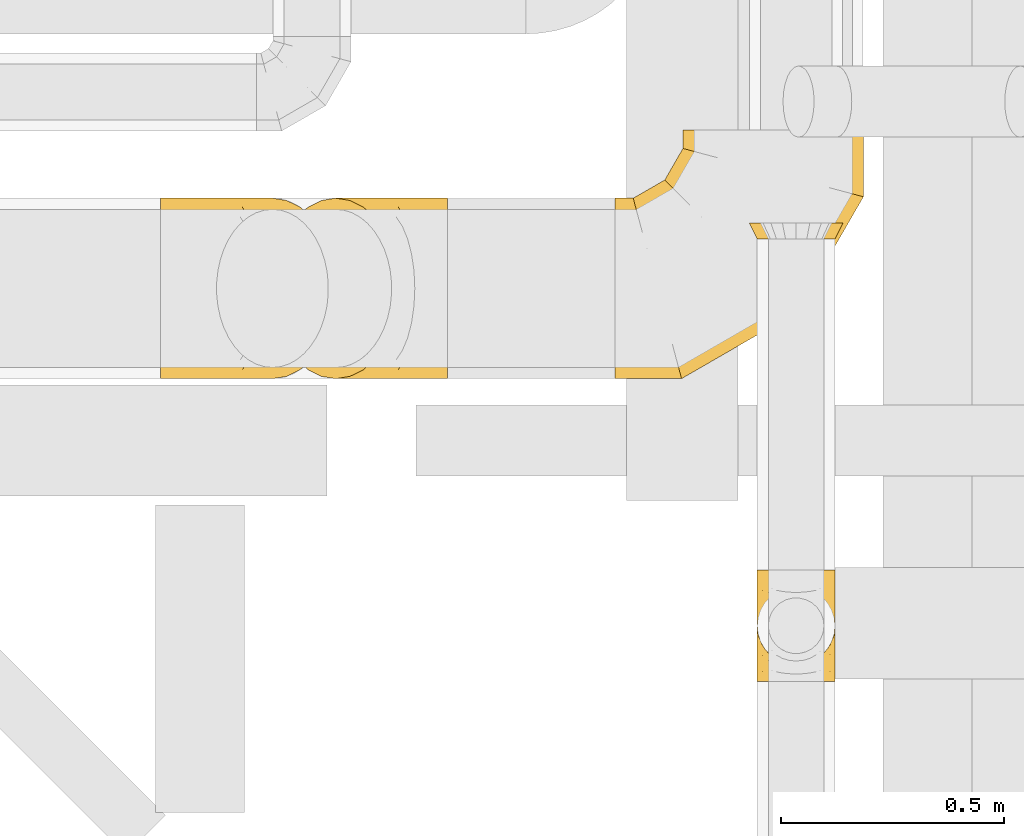
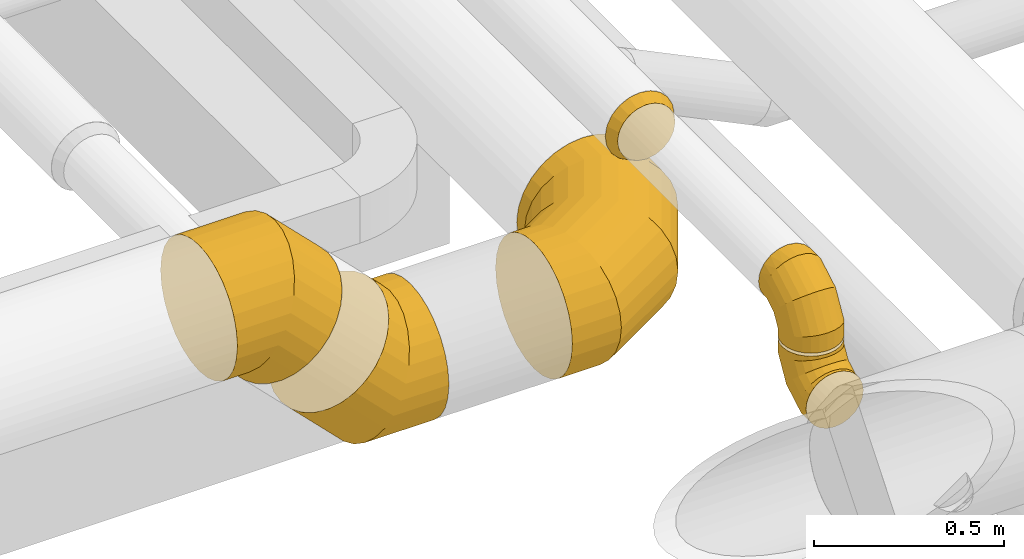
# One storey, part 12 of 337: 6 coverings.
"""IFC2X3 building model written with IfcOpenShell, lengths in millimetres."""

from ifc_helpers import new_model, entity, si_unit, converted_unit, derived_unit, direction, frame, origin, place, context, subcontext, project, spatial, faceted_brep, element, save


model = new_model("IFC2X3")

# Units and contexts
model_context = context("Model", 3, precision=0.01, world=origin(), true_north=direction((6.12303176911189e-17, 1.0)))
body_context = subcontext(model_context, "Body", "Model", "MODEL_VIEW")
ifc_project = project(units=[si_unit("LENGTHUNIT", "METRE", prefix="MILLI"), si_unit("AREAUNIT", "SQUARE_METRE"), si_unit("VOLUMEUNIT", "CUBIC_METRE"), converted_unit("PLANEANGLEUNIT", "DEGREE", entity("IfcRatioMeasure", 0.0174532925199433), si_unit("PLANEANGLEUNIT", "RADIAN"), dimensions=[0, 0, 0, 0, 0, 0, 0]), si_unit("MASSUNIT", "GRAM", prefix="KILO"), derived_unit("MASSDENSITYUNIT", [(si_unit("MASSUNIT", "GRAM", prefix="KILO"), 1), (si_unit("LENGTHUNIT", "METRE"), -3)]), derived_unit("MOMENTOFINERTIAUNIT", [(si_unit("LENGTHUNIT", "METRE"), 4)]), si_unit("TIMEUNIT", "SECOND"), si_unit("FREQUENCYUNIT", "HERTZ"), si_unit("THERMODYNAMICTEMPERATUREUNIT", "DEGREE_CELSIUS"), derived_unit("THERMALTRANSMITTANCEUNIT", [(si_unit("MASSUNIT", "GRAM", prefix="KILO"), 1), (si_unit("THERMODYNAMICTEMPERATUREUNIT", "KELVIN"), -1), (si_unit("TIMEUNIT", "SECOND"), -3)]), derived_unit("VOLUMETRICFLOWRATEUNIT", [(si_unit("LENGTHUNIT", "METRE"), 3), (si_unit("TIMEUNIT", "SECOND"), -1)]), derived_unit("MASSFLOWRATEUNIT", [(si_unit("MASSUNIT", "GRAM", prefix="KILO"), 1), (si_unit("TIMEUNIT", "SECOND"), -1)]), derived_unit("ROTATIONALFREQUENCYUNIT", [(si_unit("TIMEUNIT", "SECOND"), -1)]), si_unit("ELECTRICCURRENTUNIT", "AMPERE"), si_unit("ELECTRICVOLTAGEUNIT", "VOLT"), si_unit("POWERUNIT", "WATT"), si_unit("FORCEUNIT", "NEWTON", prefix="KILO"), si_unit("ILLUMINANCEUNIT", "LUX"), si_unit("LUMINOUSFLUXUNIT", "LUMEN"), si_unit("LUMINOUSINTENSITYUNIT", "CANDELA"), derived_unit("USERDEFINED", [(si_unit("MASSUNIT", "GRAM", prefix="KILO"), -1), (si_unit("LENGTHUNIT", "METRE"), -2), (si_unit("TIMEUNIT", "SECOND"), 3), (si_unit("LUMINOUSFLUXUNIT", "LUMEN"), 1)]), derived_unit("LINEARVELOCITYUNIT", [(si_unit("LENGTHUNIT", "METRE"), 1), (si_unit("TIMEUNIT", "SECOND"), -1)]), si_unit("PRESSUREUNIT", "PASCAL"), derived_unit("USERDEFINED", [(si_unit("LENGTHUNIT", "METRE"), -2), (si_unit("MASSUNIT", "GRAM", prefix="KILO"), 1), (si_unit("TIMEUNIT", "SECOND"), -2)]), derived_unit("LINEARFORCEUNIT", [(si_unit("MASSUNIT", "GRAM", prefix="KILO"), 1), (si_unit("LENGTHUNIT", "METRE"), 1), (si_unit("TIMEUNIT", "SECOND"), -2), (si_unit("LENGTHUNIT", "METRE"), -1)]), derived_unit("PLANARFORCEUNIT", [(si_unit("MASSUNIT", "GRAM", prefix="KILO"), 1), (si_unit("LENGTHUNIT", "METRE"), 1), (si_unit("TIMEUNIT", "SECOND"), -2), (si_unit("LENGTHUNIT", "METRE"), -2)])], contexts=[model_context])

# Site, building, storey
site_placement = place(None, origin())
site = spatial("IfcSite", under=ifc_project, at=site_placement, CompositionType="ELEMENT")
building_placement = place(site_placement, origin())
building = spatial("IfcBuilding", under=site, at=building_placement, CompositionType="ELEMENT")
storey_placement = place(building_placement, origin())
storey = spatial("IfcBuildingStorey", under=building, at=storey_placement, CompositionType="ELEMENT", Elevation=0.0)

# Coverings
covering_1_placement = place(storey_placement, frame((65645.58, 2582.18, 3050.9)))
element("IfcCovering", 1, at=covering_1_placement, inside=storey, PredefinedType="INSULATION", context=body_context, shape_type="Brep", body=[
    faceted_brep([(172.31, 97.96, 214.1), (176.6, 125.0, 214.1), (172.31, 152.04, 214.1), (159.88, 176.43, 214.1), (140.53, 195.79, 214.1), (116.13, 208.22, 214.1), (89.1, 212.5, 214.1), (62.06, 208.22, 214.1), (37.66, 195.79, 214.1), (18.31, 176.43, 214.1), (5.88, 152.04, 214.1), (1.6, 125.0, 214.1), (5.88, 97.96, 214.1), (18.31, 73.57, 214.1), (37.66, 54.21, 214.1), (49.86, 48.0, 214.1), (62.06, 41.78, 214.1), (75.58, 39.64, 214.1), (89.1, 37.5, 214.1), (102.61, 39.64, 214.1), (116.13, 41.78, 214.1), (128.33, 48.0, 214.1), (140.53, 54.21, 214.1), (159.88, 73.57, 214.1), (45.35, 0.0, 13.32), (66.45, 0.0, 4.58), (89.1, 0.0, 1.6), (111.74, 0.0, 4.58), (132.85, 0.0, 13.32), (150.97, 0.0, 27.22), (164.87, 0.0, 45.35), (173.61, 0.0, 66.45), (176.6, 0.0, 89.1), (173.61, 0.0, 111.74), (164.87, 0.0, 132.85), (150.97, 0.0, 150.97), (132.85, 0.0, 164.87), (111.74, 0.0, 173.61), (89.1, 0.0, 176.6), (66.45, 0.0, 173.61), (45.35, 0.0, 164.87), (27.22, 0.0, 150.97), (13.32, 0.0, 132.85), (4.58, 0.0, 111.74), (1.6, 0.0, 89.1), (4.58, 0.0, 66.45), (13.32, 0.0, 45.35), (27.22, 0.0, 27.22), (89.1, 56.94, 1.6), (111.74, 56.14, 4.58), (132.85, 53.8, 13.32), (150.97, 50.07, 27.22), (164.87, 45.22, 45.35), (173.61, 39.56, 66.45), (176.6, 33.49, 89.1), (173.61, 27.43, 111.74), (164.87, 21.77, 132.85), (150.97, 16.92, 150.97), (132.85, 13.19, 164.87), (111.74, 10.85, 173.61), (89.1, 10.05, 176.6), (66.45, 10.85, 173.61), (45.35, 13.19, 164.87), (27.22, 16.92, 150.97), (4.58, 27.43, 111.74), (1.6, 33.49, 89.1), (13.32, 21.77, 132.85), (4.58, 39.56, 66.45), (13.32, 45.22, 45.35), (27.22, 50.07, 27.22), (45.35, 53.8, 13.32), (66.45, 56.14, 4.58), (89.1, 155.56, 58.53), (111.74, 153.38, 60.72), (132.85, 146.98, 67.12), (150.97, 136.8, 77.3), (164.87, 123.53, 90.56), (173.61, 108.08, 106.01), (176.6, 91.51, 122.59), (173.61, 74.93, 139.17), (164.87, 59.48, 154.62), (150.97, 46.21, 167.88), (132.85, 36.03, 178.06), (111.74, 29.63, 184.46), (89.1, 27.45, 186.64), (66.45, 29.63, 184.46), (45.35, 36.03, 178.06), (27.22, 46.21, 167.88), (4.58, 74.93, 139.17), (1.6, 91.51, 122.59), (13.32, 59.48, 154.62), (4.58, 108.08, 106.01), (13.32, 123.53, 90.56), (27.22, 136.8, 77.3), (45.35, 146.98, 67.12), (66.45, 153.38, 60.72), (89.1, 212.5, 157.16), (111.74, 209.52, 157.95), (132.85, 200.78, 160.3), (150.97, 186.87, 164.02), (164.87, 168.75, 168.88), (173.61, 147.65, 174.53), (176.6, 125.0, 180.6), (173.61, 102.35, 186.67), (164.87, 81.25, 192.32), (150.97, 63.13, 197.18), (132.85, 49.22, 200.91), (111.74, 40.48, 203.25), (100.42, 38.99, 203.65), (89.1, 37.5, 204.05), (66.45, 40.48, 203.25), (45.35, 49.22, 200.91), (77.77, 38.99, 203.65), (27.22, 63.13, 197.18), (4.58, 102.35, 186.67), (1.6, 125.0, 180.6), (13.32, 81.25, 192.32), (4.58, 147.65, 174.53), (13.32, 168.75, 168.88), (27.22, 186.87, 164.02), (45.35, 200.78, 160.3), (66.45, 209.52, 157.95)], [[[0, 1, 2, 3, 4, 5, 6, 7, 8, 9, 10, 11, 12, 13, 14, 15, 16, 17, 18, 19, 20, 21, 22, 23]], [[24, 25, 26, 27, 28, 29, 30, 31, 32, 33, 34, 35, 36, 37, 38, 39, 40, 41, 42, 43, 44, 45, 46, 47]], [[26, 48, 49, 27]], [[27, 49, 50, 28]], [[28, 50, 51, 29]], [[30, 52, 53, 31]], [[31, 53, 54, 32]], [[29, 51, 52, 30]], [[55, 56, 34, 33]], [[54, 55, 33, 32]], [[57, 35, 34, 56]], [[58, 59, 37, 36]], [[58, 36, 35, 57]], [[60, 38, 37, 59]], [[61, 62, 40, 39]], [[60, 61, 39, 38]], [[41, 40, 62, 63]], [[64, 65, 44, 43]], [[66, 64, 43, 42]], [[63, 66, 42, 41]], [[46, 45, 67, 68]], [[47, 46, 68, 69]], [[44, 65, 67, 45]], [[25, 24, 70, 71]], [[26, 25, 71, 48]], [[69, 70, 24, 47]], [[49, 48, 72, 73]], [[50, 49, 73, 74]], [[74, 75, 51, 50]], [[52, 51, 75, 76]], [[53, 52, 76, 77]], [[54, 53, 77, 78]], [[79, 80, 56, 55]], [[78, 79, 55, 54]], [[57, 56, 80, 81]], [[82, 83, 59, 58]], [[81, 82, 58, 57]], [[60, 59, 83, 84]], [[85, 86, 62, 61]], [[84, 85, 61, 60]], [[63, 62, 86, 87]], [[88, 89, 65, 64]], [[90, 88, 64, 66]], [[87, 90, 66, 63]], [[67, 65, 89, 91]], [[68, 67, 91, 92]], [[69, 68, 92, 93]], [[71, 70, 94, 95]], [[48, 71, 95, 72]], [[93, 94, 70, 69]], [[73, 72, 96, 97]], [[74, 73, 97, 98]], [[98, 99, 75, 74]], [[76, 75, 99, 100]], [[77, 76, 100, 101]], [[78, 77, 101, 102]], [[103, 104, 80, 79]], [[102, 103, 79, 78]], [[81, 80, 104, 105]], [[106, 107, 83, 82]], [[105, 106, 82, 81]], [[84, 83, 107, 108, 109]], [[110, 111, 86, 85]], [[85, 84, 109, 112, 110]], [[87, 86, 111, 113]], [[114, 115, 89, 88]], [[116, 114, 88, 90]], [[113, 116, 90, 87]], [[91, 89, 115, 117]], [[92, 91, 117, 118]], [[93, 92, 118, 119]], [[95, 94, 120, 121]], [[72, 95, 121, 96]], [[119, 120, 94, 93]], [[97, 6, 5]], [[98, 5, 4]], [[6, 97, 96]], [[97, 5, 98]], [[4, 99, 98]], [[100, 3, 2]], [[101, 2, 1]], [[99, 3, 100]], [[100, 2, 101]], [[1, 102, 101]], [[3, 99, 4]], [[103, 1, 0]], [[104, 0, 23]], [[103, 102, 1]], [[104, 103, 0]], [[23, 105, 104]], [[21, 20, 107]], [[18, 109, 108]], [[107, 20, 19]], [[106, 105, 22]], [[106, 22, 21]], [[107, 19, 108]], [[21, 107, 106]], [[18, 108, 19]], [[22, 105, 23]], [[110, 17, 16]], [[111, 15, 14]], [[18, 112, 109]], [[18, 17, 112]], [[110, 16, 15]], [[110, 15, 111]], [[14, 113, 111]], [[116, 13, 12]], [[114, 12, 11]], [[116, 113, 13]], [[115, 114, 11]], [[116, 12, 114]], [[17, 110, 112]], [[13, 113, 14]], [[117, 11, 10]], [[118, 10, 9]], [[11, 117, 115]], [[117, 10, 118]], [[9, 119, 118]], [[120, 8, 7]], [[121, 7, 6]], [[119, 8, 120]], [[121, 120, 7]], [[96, 121, 6]], [[8, 119, 9]]]),
])
covering_2_placement = place(storey_placement, frame((65645.58, 2618.09, 3275.0)))
element("IfcCovering", 2, at=covering_2_placement, inside=storey, PredefinedType="INSULATION", context=body_context, shape_type="Brep", body=[
    faceted_brep([(5.88, 214.1, 97.96), (1.6, 214.1, 125.0), (5.88, 214.1, 152.04), (18.31, 214.1, 176.43), (37.66, 214.1, 195.79), (62.06, 214.1, 208.22), (89.1, 214.1, 212.5), (116.13, 214.1, 208.22), (140.53, 214.1, 195.79), (159.88, 214.1, 176.43), (172.31, 214.1, 152.04), (176.6, 214.1, 125.0), (172.31, 214.1, 97.96), (159.88, 214.1, 73.57), (140.53, 214.1, 54.21), (128.33, 214.1, 48.0), (116.13, 214.1, 41.78), (102.61, 214.1, 39.64), (89.1, 214.1, 37.5), (75.58, 214.1, 39.64), (62.06, 214.1, 41.78), (49.86, 214.1, 48.0), (37.66, 214.1, 54.21), (18.31, 214.1, 73.57), (132.85, 13.32, 0.0), (111.74, 4.58, 0.0), (89.1, 1.6, 0.0), (66.45, 4.58, 0.0), (45.35, 13.32, 0.0), (27.22, 27.22, 0.0), (13.32, 45.35, 0.0), (4.58, 66.45, 0.0), (1.6, 89.1, 0.0), (4.58, 111.74, 0.0), (13.32, 132.85, 0.0), (27.22, 150.97, 0.0), (45.35, 164.87, 0.0), (66.45, 173.61, 0.0), (89.1, 176.6, 0.0), (111.74, 173.61, 0.0), (132.85, 164.87, 0.0), (150.97, 150.97, 0.0), (164.87, 132.85, 0.0), (173.61, 111.74, 0.0), (176.6, 89.1, 0.0), (173.61, 66.45, 0.0), (164.87, 45.35, 0.0), (150.97, 27.22, 0.0), (89.1, 1.6, 56.94), (66.45, 4.58, 56.14), (45.35, 13.32, 53.8), (27.22, 27.22, 50.07), (13.32, 45.35, 45.22), (4.58, 66.45, 39.56), (1.6, 89.1, 33.49), (4.58, 111.74, 27.43), (13.32, 132.85, 21.77), (27.22, 150.97, 16.92), (45.35, 164.87, 13.19), (66.45, 173.61, 10.85), (89.1, 176.6, 10.05), (111.74, 173.61, 10.85), (132.85, 164.87, 13.19), (150.97, 150.97, 16.92), (173.61, 111.74, 27.43), (176.6, 89.1, 33.49), (164.87, 132.85, 21.77), (173.61, 66.45, 39.56), (164.87, 45.35, 45.22), (150.97, 27.22, 50.07), (132.85, 13.32, 53.8), (111.74, 4.58, 56.14), (89.1, 58.53, 155.56), (66.45, 60.72, 153.38), (45.35, 67.12, 146.98), (27.22, 77.3, 136.8), (13.32, 90.56, 123.53), (4.58, 106.01, 108.08), (1.6, 122.59, 91.51), (4.58, 139.17, 74.93), (13.32, 154.62, 59.48), (27.22, 167.88, 46.21), (45.35, 178.06, 36.03), (66.45, 184.46, 29.63), (89.1, 186.64, 27.45), (111.74, 184.46, 29.63), (132.85, 178.06, 36.03), (150.97, 167.88, 46.21), (173.61, 139.17, 74.93), (176.6, 122.59, 91.51), (164.87, 154.62, 59.48), (173.61, 106.01, 108.08), (164.87, 90.56, 123.53), (150.97, 77.3, 136.8), (132.85, 67.12, 146.98), (111.74, 60.72, 153.38), (89.1, 157.16, 212.5), (66.45, 157.95, 209.52), (45.35, 160.3, 200.78), (27.22, 164.02, 186.87), (13.32, 168.88, 168.75), (4.58, 174.53, 147.65), (1.6, 180.6, 125.0), (4.58, 186.67, 102.35), (13.32, 192.32, 81.25), (27.22, 197.18, 63.13), (45.35, 200.91, 49.22), (66.45, 203.25, 40.48), (77.77, 203.65, 38.99), (89.1, 204.05, 37.5), (111.74, 203.25, 40.48), (132.85, 200.91, 49.22), (100.42, 203.65, 38.99), (150.97, 197.18, 63.13), (173.61, 186.67, 102.35), (176.6, 180.6, 125.0), (164.87, 192.32, 81.25), (173.61, 174.53, 147.65), (164.87, 168.88, 168.75), (150.97, 164.02, 186.87), (132.85, 160.3, 200.78), (111.74, 157.95, 209.52)], [[[0, 1, 2, 3, 4, 5, 6, 7, 8, 9, 10, 11, 12, 13, 14, 15, 16, 17, 18, 19, 20, 21, 22, 23]], [[24, 25, 26, 27, 28, 29, 30, 31, 32, 33, 34, 35, 36, 37, 38, 39, 40, 41, 42, 43, 44, 45, 46, 47]], [[26, 48, 49, 27]], [[27, 49, 50, 28]], [[28, 50, 51, 29]], [[30, 52, 53, 31]], [[31, 53, 54, 32]], [[29, 51, 52, 30]], [[55, 56, 34, 33]], [[54, 55, 33, 32]], [[57, 35, 34, 56]], [[58, 59, 37, 36]], [[58, 36, 35, 57]], [[60, 38, 37, 59]], [[61, 62, 40, 39]], [[60, 61, 39, 38]], [[41, 40, 62, 63]], [[64, 65, 44, 43]], [[66, 64, 43, 42]], [[63, 66, 42, 41]], [[46, 45, 67, 68]], [[47, 46, 68, 69]], [[44, 65, 67, 45]], [[25, 24, 70, 71]], [[26, 25, 71, 48]], [[69, 70, 24, 47]], [[49, 48, 72, 73]], [[50, 49, 73, 74]], [[74, 75, 51, 50]], [[52, 51, 75, 76]], [[53, 52, 76, 77]], [[54, 53, 77, 78]], [[79, 80, 56, 55]], [[78, 79, 55, 54]], [[57, 56, 80, 81]], [[82, 83, 59, 58]], [[81, 82, 58, 57]], [[60, 59, 83, 84]], [[85, 86, 62, 61]], [[84, 85, 61, 60]], [[63, 62, 86, 87]], [[88, 89, 65, 64]], [[90, 88, 64, 66]], [[87, 90, 66, 63]], [[67, 65, 89, 91]], [[68, 67, 91, 92]], [[69, 68, 92, 93]], [[71, 70, 94, 95]], [[48, 71, 95, 72]], [[93, 94, 70, 69]], [[73, 72, 96, 97]], [[74, 73, 97, 98]], [[98, 99, 75, 74]], [[76, 75, 99, 100]], [[77, 76, 100, 101]], [[78, 77, 101, 102]], [[103, 104, 80, 79]], [[102, 103, 79, 78]], [[81, 80, 104, 105]], [[106, 107, 83, 82]], [[105, 106, 82, 81]], [[84, 83, 107, 108, 109]], [[110, 111, 86, 85]], [[85, 84, 109, 112, 110]], [[87, 86, 111, 113]], [[114, 115, 89, 88]], [[116, 114, 88, 90]], [[113, 116, 90, 87]], [[91, 89, 115, 117]], [[92, 91, 117, 118]], [[93, 92, 118, 119]], [[95, 94, 120, 121]], [[72, 95, 121, 96]], [[119, 120, 94, 93]], [[97, 6, 5]], [[98, 5, 4]], [[6, 97, 96]], [[97, 5, 98]], [[4, 99, 98]], [[100, 3, 2]], [[101, 2, 1]], [[99, 3, 100]], [[100, 2, 101]], [[1, 102, 101]], [[3, 99, 4]], [[103, 1, 0]], [[104, 0, 23]], [[103, 102, 1]], [[104, 103, 0]], [[23, 105, 104]], [[21, 20, 107]], [[18, 109, 108]], [[107, 20, 19]], [[106, 105, 22]], [[106, 22, 21]], [[107, 19, 108]], [[21, 107, 106]], [[18, 108, 19]], [[22, 105, 23]], [[110, 17, 16]], [[111, 15, 14]], [[18, 112, 109]], [[18, 17, 112]], [[110, 16, 15]], [[110, 15, 111]], [[14, 113, 111]], [[116, 13, 12]], [[114, 12, 11]], [[116, 113, 13]], [[115, 114, 11]], [[116, 12, 114]], [[17, 110, 112]], [[13, 113, 14]], [[117, 11, 10]], [[118, 10, 9]], [[11, 117, 115]], [[117, 10, 118]], [[9, 119, 118]], [[120, 8, 7]], [[121, 7, 6]], [[119, 8, 120]], [[121, 120, 7]], [[96, 121, 6]], [[8, 119, 9]]]),
])
covering_3_placement = place(storey_placement, frame((65628.08, 3575.46, 3293.4)))
element("IfcCovering", 3, at=covering_3_placement, inside=storey, PredefinedType="INSULATION", context=body_context, shape_type="Brep", body=[
    faceted_brep([(139.04, 35.0, 206.46), (168.31, 35.0, 191.54), (191.54, 35.0, 168.31), (206.46, 35.0, 139.04), (211.6, 35.0, 106.6), (206.46, 35.0, 74.15), (191.54, 35.0, 44.88), (168.31, 35.0, 21.65), (139.04, 35.0, 6.73), (106.6, 35.0, 1.6), (74.15, 35.0, 6.73), (44.88, 35.0, 21.65), (21.65, 35.0, 44.88), (6.73, 35.0, 74.15), (1.6, 35.0, 106.6), (6.73, 35.0, 139.04), (21.65, 35.0, 168.31), (44.88, 35.0, 191.54), (74.15, 35.0, 206.46), (106.6, 35.0, 211.6), (133.63, 0.0, 189.81), (106.6, 0.0, 194.1), (79.56, 0.0, 189.81), (55.16, 0.0, 177.38), (35.81, 0.0, 158.03), (23.38, 0.0, 133.63), (19.1, 0.0, 106.6), (23.38, 0.0, 79.56), (35.81, 0.0, 55.16), (55.16, 0.0, 35.81), (79.56, 0.0, 23.38), (106.6, 0.0, 19.1), (133.63, 0.0, 23.38), (158.03, 0.0, 35.81), (177.38, 0.0, 55.16), (189.81, 0.0, 79.56), (194.1, 0.0, 106.6), (189.81, 0.0, 133.63), (177.38, 0.0, 158.03), (158.03, 0.0, 177.38)], [[[0, 1, 2, 3, 4, 5, 6, 7, 8, 9, 10, 11, 12, 13, 14, 15, 16, 17, 18, 19]], [[20, 21, 22, 23, 24, 25, 26, 27, 28, 29, 30, 31, 32, 33, 34, 35, 36, 37, 38, 39]], [[35, 34, 6, 5]], [[36, 35, 5, 4]], [[34, 33, 7, 6]], [[8, 7, 33, 32]], [[8, 32, 31, 9]], [[30, 29, 11, 10]], [[31, 30, 10, 9]], [[29, 28, 12, 11]], [[13, 12, 28, 27]], [[13, 27, 26, 14]], [[25, 24, 16, 15]], [[26, 25, 15, 14]], [[24, 23, 17, 16]], [[18, 17, 23, 22]], [[18, 22, 21, 19]], [[20, 39, 1, 0]], [[21, 20, 0, 19]], [[39, 38, 2, 1]], [[3, 2, 38, 37]], [[3, 37, 36, 4]]]),
])
covering_4_placement = place(storey_placement, frame((64308.4, 3260.06, 3151.24)))
element("IfcCovering", 4, at=covering_4_placement, inside=storey, PredefinedType="INSULATION", context=body_context, shape_type="Brep", body=[
    faceted_brep([(111.42, 249.16, 5.19), (122.01, 291.96, 15.78), (139.07, 330.35, 32.83), (161.75, 362.42, 55.51), (188.9, 386.54, 82.66), (219.16, 401.52, 112.92), (251.02, 406.6, 144.78), (282.89, 401.52, 176.65), (313.15, 386.54, 206.91), (340.3, 362.42, 234.06), (362.97, 330.35, 256.73), (380.03, 291.96, 273.79), (390.62, 249.16, 284.38), (394.21, 204.1, 287.97), (390.62, 159.03, 284.38), (380.03, 116.23, 273.79), (362.97, 77.84, 256.73), (340.3, 45.77, 234.06), (313.15, 21.65, 206.91), (282.89, 6.67, 176.65), (251.02, 1.6, 144.78), (219.16, 6.67, 112.92), (188.9, 21.65, 82.66), (161.75, 45.77, 55.51), (139.07, 77.84, 32.83), (122.01, 116.23, 15.78), (111.42, 159.03, 5.19), (107.83, 204.1, 1.6), (0.0, 77.84, 407.08), (0.0, 116.23, 431.21), (0.0, 159.03, 446.18), (0.0, 204.1, 451.26), (0.0, 249.16, 446.18), (0.0, 291.96, 431.21), (0.0, 330.35, 407.08), (0.0, 362.42, 375.02), (0.0, 386.54, 336.62), (0.0, 401.52, 293.82), (0.0, 406.6, 248.76), (0.0, 401.52, 203.7), (0.0, 386.54, 160.9), (0.0, 362.42, 122.5), (0.0, 330.35, 90.44), (0.0, 291.96, 66.32), (0.0, 249.16, 51.34), (0.0, 204.1, 46.26), (0.0, 159.03, 51.34), (0.0, 116.23, 66.32), (0.0, 77.84, 90.44), (0.0, 45.77, 122.5), (0.0, 21.65, 160.9), (0.0, 6.67, 203.7), (0.0, 1.6, 248.76), (0.0, 6.67, 293.82), (0.0, 21.65, 336.62), (0.0, 45.77, 375.02), (230.92, 204.1, 451.26), (228.82, 249.16, 446.18), (222.62, 291.96, 431.21), (212.62, 330.35, 407.08), (199.34, 362.42, 375.02), (183.44, 386.54, 336.62), (165.71, 401.52, 293.82), (147.05, 406.6, 248.76), (128.38, 401.52, 203.7), (110.65, 386.54, 160.9), (94.75, 362.42, 122.5), (81.47, 330.35, 90.44), (71.47, 291.96, 66.32), (65.27, 249.16, 51.34), (63.17, 204.1, 46.26), (65.27, 159.03, 51.34), (71.47, 116.23, 66.32), (81.47, 77.84, 90.44), (94.75, 45.77, 122.5), (110.65, 21.65, 160.9), (128.38, 6.67, 203.7), (147.05, 1.6, 248.76), (165.71, 6.67, 293.82), (183.44, 21.65, 336.62), (199.34, 45.77, 375.02), (212.62, 77.84, 407.08), (222.62, 116.23, 431.21), (228.82, 159.03, 446.18)], [[[0, 1, 2, 3, 4, 5, 6, 7, 8, 9, 10, 11, 12, 13, 14, 15, 16, 17, 18, 19, 20, 21, 22, 23, 24, 25, 26, 27]], [[28, 29, 30, 31, 32, 33, 34, 35, 36, 37, 38, 39, 40, 41, 42, 43, 44, 45, 46, 47, 48, 49, 50, 51, 52, 53, 54, 55]], [[31, 56, 57, 32]], [[32, 57, 58, 33]], [[33, 58, 59, 34]], [[59, 60, 35, 34]], [[35, 60, 61, 36]], [[36, 61, 62, 37]], [[37, 62, 63, 38]], [[63, 64, 39, 38]], [[65, 66, 41, 40]], [[64, 65, 40, 39]], [[66, 67, 42, 41]], [[67, 68, 43, 42]], [[69, 70, 45, 44]], [[68, 69, 44, 43]], [[70, 71, 46, 45]], [[72, 73, 48, 47]], [[71, 72, 47, 46]], [[73, 74, 49, 48]], [[74, 75, 50, 49]], [[76, 77, 52, 51]], [[75, 76, 51, 50]], [[53, 52, 77, 78]], [[78, 79, 54, 53]], [[80, 55, 54, 79]], [[80, 81, 28, 55]], [[29, 28, 81, 82]], [[82, 83, 30, 29]], [[56, 31, 30, 83]], [[13, 12, 57, 56]], [[11, 10, 59, 58]], [[12, 11, 58, 57]], [[10, 9, 60, 59]], [[61, 60, 9, 8]], [[62, 61, 8, 7]], [[63, 62, 7, 6]], [[64, 63, 6, 5]], [[65, 64, 5, 4]], [[66, 65, 4, 3]], [[3, 2, 67, 66]], [[68, 67, 2, 1]], [[69, 68, 1, 0]], [[70, 69, 0, 27]], [[70, 27, 26, 71]], [[71, 26, 25, 72]], [[72, 25, 24, 73]], [[24, 23, 74, 73]], [[74, 23, 22, 75]], [[75, 22, 21, 76]], [[76, 21, 20, 77]], [[77, 20, 19, 78]], [[78, 19, 18, 79]], [[79, 18, 17, 80]], [[17, 16, 81, 80]], [[81, 16, 15, 82]], [[82, 15, 14, 83]], [[83, 14, 13, 56]]]),
])
covering_5_placement = place(storey_placement, frame((65328.23, 3260.06, 2845.9)))
element("IfcCovering", 5, at=covering_5_placement, inside=storey, PredefinedType="INSULATION", context=body_context, shape_type="Brep", body=[
    faceted_brep([(400.06, 559.1, 401.52), (442.86, 559.1, 386.54), (481.26, 559.1, 362.42), (513.32, 559.1, 330.35), (537.45, 559.1, 291.96), (552.42, 559.1, 249.16), (557.5, 559.1, 204.1), (552.42, 559.1, 159.03), (537.45, 559.1, 116.23), (513.32, 559.1, 77.84), (481.26, 559.1, 45.77), (442.86, 559.1, 21.65), (400.06, 559.1, 6.67), (355.0, 559.1, 1.6), (309.94, 559.1, 6.67), (267.14, 559.1, 21.65), (228.74, 559.1, 45.77), (196.68, 559.1, 77.84), (172.55, 559.1, 116.23), (157.58, 559.1, 159.03), (152.5, 559.1, 204.1), (157.58, 559.1, 249.16), (172.55, 559.1, 291.96), (196.68, 559.1, 330.35), (228.74, 559.1, 362.42), (267.14, 559.1, 386.54), (309.94, 559.1, 401.52), (355.0, 559.1, 406.6), (0.0, 45.77, 77.84), (0.0, 21.65, 116.23), (0.0, 6.67, 159.03), (0.0, 1.6, 204.1), (0.0, 6.67, 249.16), (0.0, 21.65, 291.96), (0.0, 45.77, 330.35), (0.0, 77.84, 362.42), (0.0, 116.23, 386.54), (0.0, 159.03, 401.52), (0.0, 204.1, 406.6), (0.0, 249.16, 401.52), (0.0, 291.96, 386.54), (0.0, 330.35, 362.42), (0.0, 362.42, 330.35), (0.0, 386.54, 291.96), (0.0, 401.52, 249.16), (0.0, 406.6, 204.1), (0.0, 401.52, 159.03), (0.0, 386.54, 116.23), (0.0, 362.42, 77.84), (0.0, 330.35, 45.77), (0.0, 291.96, 21.65), (0.0, 249.16, 6.67), (0.0, 204.1, 1.6), (0.0, 159.03, 6.67), (0.0, 116.23, 21.65), (0.0, 77.84, 45.77), (149.38, 1.6, 204.1), (148.02, 6.67, 249.16), (144.01, 21.65, 291.96), (137.54, 45.77, 330.35), (128.95, 77.84, 362.42), (118.66, 116.23, 386.54), (107.2, 159.03, 401.52), (95.12, 204.1, 406.6), (83.05, 249.16, 401.52), (71.58, 291.96, 386.54), (61.29, 330.35, 362.42), (52.7, 362.42, 330.35), (46.24, 386.54, 291.96), (42.22, 401.52, 249.16), (40.86, 406.6, 204.1), (42.22, 401.52, 159.03), (46.24, 386.54, 116.23), (52.7, 362.42, 77.84), (61.29, 330.35, 45.77), (71.58, 291.96, 21.65), (83.05, 249.16, 6.67), (95.12, 204.1, 1.6), (107.2, 159.03, 6.67), (118.66, 116.23, 21.65), (128.95, 77.84, 45.77), (137.54, 45.77, 77.84), (144.01, 21.65, 116.23), (148.02, 6.67, 159.03), (408.12, 150.98, 204.1), (404.4, 154.69, 249.16), (393.44, 165.66, 291.96), (375.78, 183.32, 330.35), (352.3, 206.79, 362.42), (324.2, 234.9, 386.54), (292.86, 266.23, 401.52), (259.88, 299.22, 406.6), (226.89, 332.2, 401.52), (195.56, 363.54, 386.54), (167.45, 391.64, 362.42), (143.98, 415.12, 330.35), (126.32, 432.78, 291.96), (115.35, 443.74, 249.16), (111.64, 447.46, 204.1), (115.35, 443.74, 159.03), (126.32, 432.78, 116.23), (143.98, 415.12, 77.84), (167.45, 391.64, 45.77), (195.56, 363.54, 21.65), (226.89, 332.2, 6.67), (259.88, 299.22, 1.6), (292.86, 266.23, 6.67), (324.2, 234.9, 21.65), (352.3, 206.79, 45.77), (375.78, 183.32, 77.84), (393.44, 165.66, 116.23), (404.4, 154.69, 159.03), (557.5, 409.71, 204.1), (552.42, 411.07, 249.16), (537.45, 415.09, 291.96), (513.32, 421.55, 330.35), (481.26, 430.14, 362.42), (442.86, 440.43, 386.54), (400.06, 451.9, 401.52), (355.0, 463.97, 406.6), (309.94, 476.05, 401.52), (267.14, 487.52, 386.54), (228.74, 497.8, 362.42), (196.68, 506.4, 330.35), (172.55, 512.86, 291.96), (157.58, 516.87, 249.16), (152.5, 518.23, 204.1), (157.58, 516.87, 159.03), (172.55, 512.86, 116.23), (196.68, 506.4, 77.84), (228.74, 497.8, 45.77), (267.14, 487.52, 21.65), (309.94, 476.05, 6.67), (355.0, 463.97, 1.6), (400.06, 451.9, 6.67), (442.86, 440.43, 21.65), (481.26, 430.14, 45.77), (513.32, 421.55, 77.84), (537.45, 415.09, 116.23), (552.42, 411.07, 159.03)], [[[0, 1, 2, 3, 4, 5, 6, 7, 8, 9, 10, 11, 12, 13, 14, 15, 16, 17, 18, 19, 20, 21, 22, 23, 24, 25, 26, 27]], [[28, 29, 30, 31, 32, 33, 34, 35, 36, 37, 38, 39, 40, 41, 42, 43, 44, 45, 46, 47, 48, 49, 50, 51, 52, 53, 54, 55]], [[31, 56, 57, 32]], [[32, 57, 58, 33]], [[33, 58, 59, 34]], [[59, 60, 35, 34]], [[35, 60, 61, 36]], [[36, 61, 62, 37]], [[37, 62, 63, 38]], [[63, 64, 39, 38]], [[65, 66, 41, 40]], [[64, 65, 40, 39]], [[66, 67, 42, 41]], [[67, 68, 43, 42]], [[69, 70, 45, 44]], [[68, 69, 44, 43]], [[70, 71, 46, 45]], [[72, 73, 48, 47]], [[71, 72, 47, 46]], [[73, 74, 49, 48]], [[74, 75, 50, 49]], [[76, 77, 52, 51]], [[75, 76, 51, 50]], [[53, 52, 77, 78]], [[78, 79, 54, 53]], [[80, 55, 54, 79]], [[80, 81, 28, 55]], [[29, 28, 81, 82]], [[82, 83, 30, 29]], [[56, 31, 30, 83]], [[57, 56, 84, 85]], [[57, 85, 86, 58]], [[59, 58, 86, 87]], [[87, 88, 60, 59]], [[61, 60, 88, 89]], [[62, 61, 89, 90]], [[63, 62, 90, 91]], [[91, 92, 64, 63]], [[93, 94, 66, 65]], [[92, 93, 65, 64]], [[94, 95, 67, 66]], [[95, 96, 68, 67]], [[97, 98, 70, 69]], [[96, 97, 69, 68]], [[98, 99, 71, 70]], [[100, 101, 73, 72]], [[99, 100, 72, 71]], [[101, 102, 74, 73]], [[102, 103, 75, 74]], [[104, 105, 77, 76]], [[103, 104, 76, 75]], [[78, 77, 105, 106]], [[106, 107, 79, 78]], [[108, 80, 79, 107]], [[108, 109, 81, 80]], [[82, 81, 109, 110]], [[110, 111, 83, 82]], [[84, 56, 83, 111]], [[85, 84, 112, 113]], [[85, 113, 114, 86]], [[87, 86, 114, 115]], [[115, 116, 88, 87]], [[89, 88, 116, 117]], [[90, 89, 117, 118]], [[91, 90, 118, 119]], [[119, 120, 92, 91]], [[121, 122, 94, 93]], [[120, 121, 93, 92]], [[122, 123, 95, 94]], [[123, 124, 96, 95]], [[125, 126, 98, 97]], [[124, 125, 97, 96]], [[126, 127, 99, 98]], [[128, 129, 101, 100]], [[127, 128, 100, 99]], [[129, 130, 102, 101]], [[130, 131, 103, 102]], [[132, 133, 105, 104]], [[131, 132, 104, 103]], [[106, 105, 133, 134]], [[134, 135, 107, 106]], [[136, 108, 107, 135]], [[136, 137, 109, 108]], [[110, 109, 137, 138]], [[138, 139, 111, 110]], [[112, 84, 111, 139]], [[113, 112, 6, 5]], [[114, 113, 5, 4]], [[115, 114, 4, 3]], [[3, 2, 116, 115]], [[117, 116, 2, 1]], [[118, 117, 1, 0]], [[119, 118, 0, 27]], [[120, 119, 27, 26]], [[25, 24, 122, 121]], [[121, 120, 26, 25]], [[24, 23, 123, 122]], [[124, 123, 23, 22]], [[125, 124, 22, 21]], [[126, 125, 21, 20]], [[126, 20, 19, 127]], [[18, 17, 129, 128]], [[127, 19, 18, 128]], [[17, 16, 130, 129]], [[130, 16, 15, 131]], [[131, 15, 14, 132]], [[132, 14, 13, 133]], [[133, 13, 12, 134]], [[134, 12, 11, 135]], [[135, 11, 10, 136]], [[10, 9, 137, 136]], [[137, 9, 8, 138]], [[138, 8, 7, 139]], [[139, 7, 6, 112]]]),
])
covering_6_placement = place(storey_placement, frame((64556.69, 3260.06, 2845.9)))
element("IfcCovering", 6, at=covering_6_placement, inside=storey, PredefinedType="INSULATION", context=body_context, shape_type="Brep", body=[
    faceted_brep([(395.81, 159.03, 401.52), (395.81, 116.23, 386.54), (395.81, 77.84, 362.42), (395.81, 45.77, 330.35), (395.81, 21.65, 291.96), (395.81, 6.67, 249.16), (395.81, 1.6, 204.1), (395.81, 6.67, 159.03), (395.81, 21.65, 116.23), (395.81, 45.77, 77.84), (395.81, 77.84, 45.77), (395.81, 116.23, 21.65), (395.81, 159.03, 6.67), (395.81, 204.1, 1.6), (395.81, 249.16, 6.67), (395.81, 291.96, 21.65), (395.81, 330.35, 45.77), (395.81, 362.42, 77.84), (395.81, 386.54, 116.23), (395.81, 401.52, 159.03), (395.81, 406.6, 204.1), (395.81, 401.52, 249.16), (395.81, 386.54, 291.96), (395.81, 362.42, 330.35), (395.81, 330.35, 362.42), (395.81, 291.96, 386.54), (395.81, 249.16, 401.52), (395.81, 204.1, 406.6), (32.83, 330.35, 196.12), (15.78, 291.96, 179.06), (5.19, 249.16, 168.47), (1.6, 204.1, 164.88), (5.19, 159.03, 168.47), (15.78, 116.23, 179.06), (32.83, 77.84, 196.12), (55.51, 45.77, 218.8), (82.66, 21.65, 245.94), (112.92, 6.67, 276.21), (144.78, 1.6, 308.07), (176.65, 6.67, 339.93), (206.91, 21.65, 370.2), (234.06, 45.77, 397.35), (256.73, 77.84, 420.02), (273.79, 116.23, 437.08), (284.38, 159.03, 447.67), (287.97, 204.1, 451.26), (284.38, 249.16, 447.67), (273.79, 291.96, 437.08), (256.73, 330.35, 420.02), (234.06, 362.42, 397.35), (206.91, 386.54, 370.2), (176.65, 401.52, 339.93), (144.78, 406.6, 308.07), (112.92, 401.52, 276.21), (82.66, 386.54, 245.94), (55.51, 362.42, 218.8), (164.88, 204.1, 1.6), (166.99, 159.03, 6.67), (173.19, 116.23, 21.65), (183.18, 77.84, 45.77), (196.46, 45.77, 77.84), (212.37, 21.65, 116.23), (230.1, 6.67, 159.03), (248.76, 1.6, 204.1), (267.43, 6.67, 249.16), (285.15, 21.65, 291.96), (301.06, 45.77, 330.35), (314.34, 77.84, 362.42), (324.33, 116.23, 386.54), (330.54, 159.03, 401.52), (332.64, 204.1, 406.6), (330.54, 249.16, 401.52), (324.33, 291.96, 386.54), (314.34, 330.35, 362.42), (301.06, 362.42, 330.35), (285.15, 386.54, 291.96), (267.43, 401.52, 249.16), (248.76, 406.6, 204.1), (230.1, 401.52, 159.03), (212.37, 386.54, 116.23), (196.46, 362.42, 77.84), (183.18, 330.35, 45.77), (173.19, 291.96, 21.65), (166.99, 249.16, 6.67)], [[[0, 1, 2, 3, 4, 5, 6, 7, 8, 9, 10, 11, 12, 13, 14, 15, 16, 17, 18, 19, 20, 21, 22, 23, 24, 25, 26, 27]], [[28, 29, 30, 31, 32, 33, 34, 35, 36, 37, 38, 39, 40, 41, 42, 43, 44, 45, 46, 47, 48, 49, 50, 51, 52, 53, 54, 55]], [[31, 56, 57, 32]], [[32, 57, 58, 33]], [[33, 58, 59, 34]], [[59, 60, 35, 34]], [[35, 60, 61, 36]], [[36, 61, 62, 37]], [[37, 62, 63, 38]], [[63, 64, 39, 38]], [[65, 66, 41, 40]], [[64, 65, 40, 39]], [[66, 67, 42, 41]], [[67, 68, 43, 42]], [[69, 70, 45, 44]], [[68, 69, 44, 43]], [[70, 71, 46, 45]], [[72, 73, 48, 47]], [[71, 72, 47, 46]], [[73, 74, 49, 48]], [[74, 75, 50, 49]], [[76, 77, 52, 51]], [[75, 76, 51, 50]], [[53, 52, 77, 78]], [[78, 79, 54, 53]], [[80, 55, 54, 79]], [[80, 81, 28, 55]], [[29, 28, 81, 82]], [[82, 83, 30, 29]], [[56, 31, 30, 83]], [[13, 12, 57, 56]], [[11, 10, 59, 58]], [[12, 11, 58, 57]], [[10, 9, 60, 59]], [[61, 60, 9, 8]], [[62, 61, 8, 7]], [[63, 62, 7, 6]], [[64, 63, 6, 5]], [[65, 64, 5, 4]], [[66, 65, 4, 3]], [[3, 2, 67, 66]], [[68, 67, 2, 1]], [[69, 68, 1, 0]], [[70, 69, 0, 27]], [[70, 27, 26, 71]], [[71, 26, 25, 72]], [[72, 25, 24, 73]], [[24, 23, 74, 73]], [[74, 23, 22, 75]], [[75, 22, 21, 76]], [[76, 21, 20, 77]], [[77, 20, 19, 78]], [[78, 19, 18, 79]], [[79, 18, 17, 80]], [[17, 16, 81, 80]], [[81, 16, 15, 82]], [[82, 15, 14, 83]], [[83, 14, 13, 56]]]),
])

save(model, "model.ifc")
